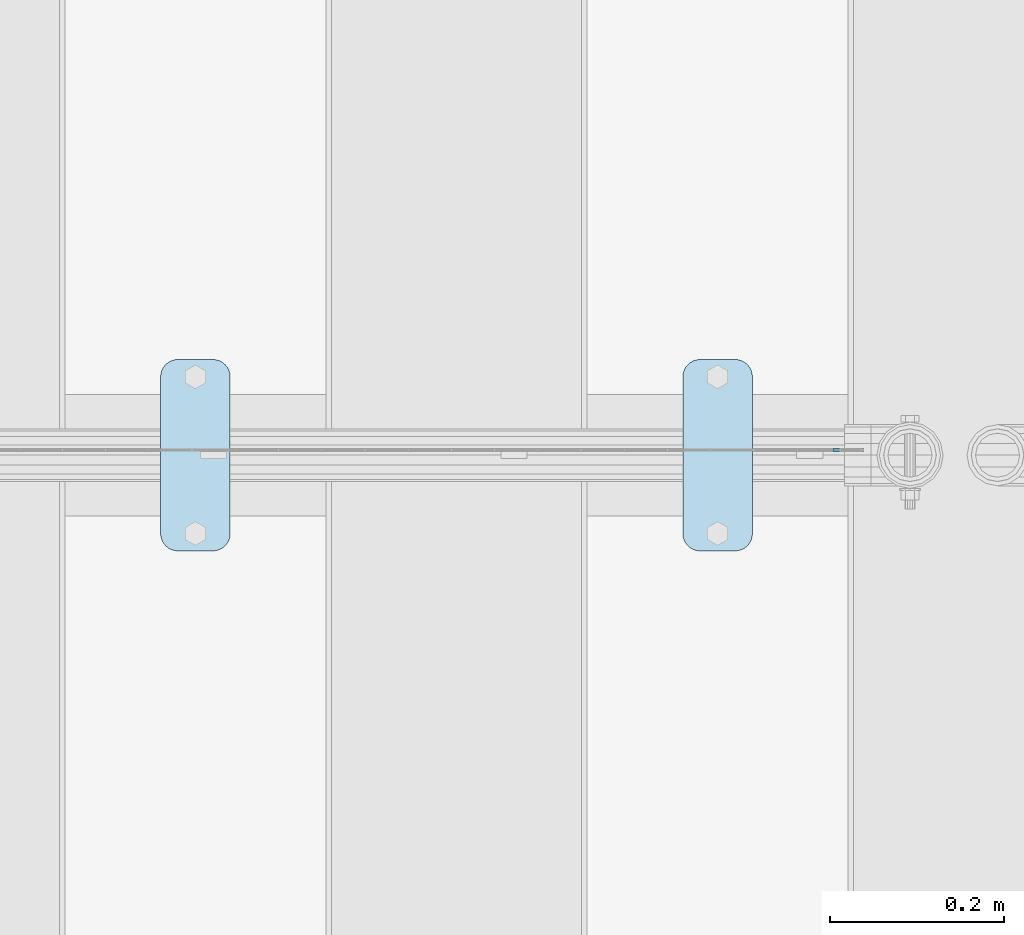
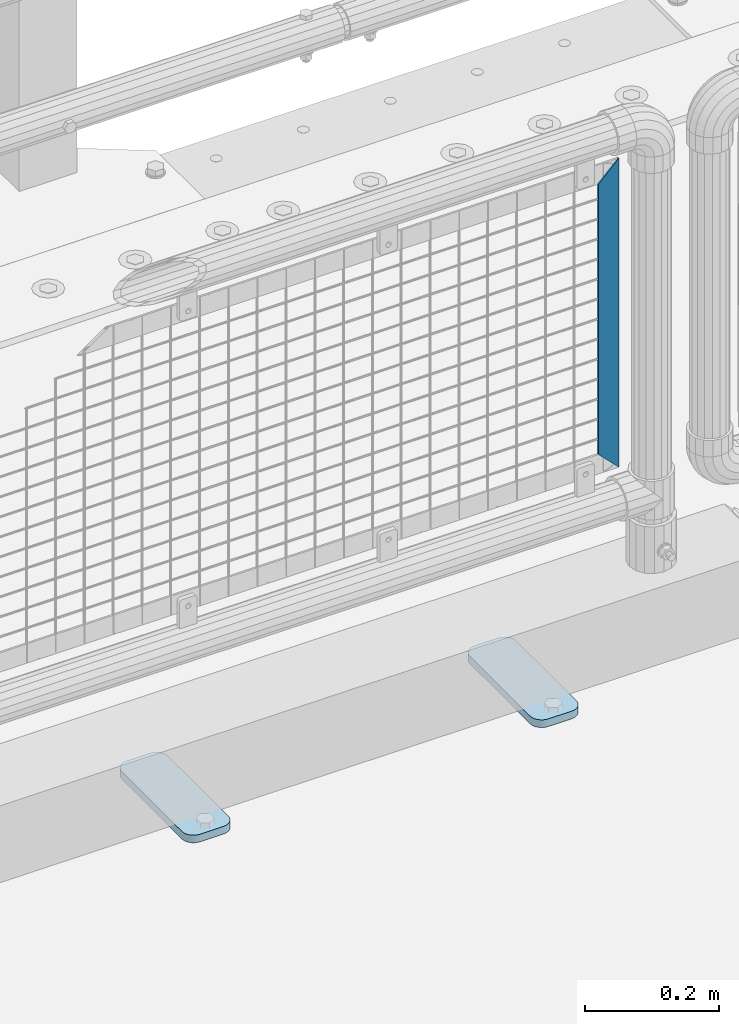
# One storey, part 229 of 257: 3 plates.
"""IFC2X3 building model written with IfcOpenShell, lengths in millimetres."""

from ifc_helpers import new_model, si_unit, frame, origin_with_axes, place, context, subcontext, project, spatial, faceted_brep, material, type_object, element, save


model = new_model("IFC2X3")

# Units and contexts
model_context = context("Model", 3, precision=1e-05, world=origin_with_axes())
body_context = subcontext(model_context, "Body", "Model", "MODEL_VIEW")
ifc_project = project(units=[si_unit("LENGTHUNIT", "METRE", prefix="MILLI"), si_unit("AREAUNIT", "SQUARE_METRE"), si_unit("VOLUMEUNIT", "CUBIC_METRE"), si_unit("MASSUNIT", "GRAM", prefix="KILO"), si_unit("TIMEUNIT", "SECOND"), si_unit("PLANEANGLEUNIT", "RADIAN"), si_unit("SOLIDANGLEUNIT", "STERADIAN"), si_unit("THERMODYNAMICTEMPERATUREUNIT", "DEGREE_CELSIUS"), si_unit("LUMINOUSINTENSITYUNIT", "LUMEN")], contexts=[model_context])

# Site, building, storey
site_placement = place(None, origin_with_axes())
site = spatial("IfcSite", under=ifc_project, at=site_placement, CompositionType="ELEMENT")
building_placement = place(site_placement, origin_with_axes())
building = spatial("IfcBuilding", under=site, at=building_placement, Name="Standard", CompositionType="ELEMENT")
storey_placement = place(building_placement, origin_with_axes())
storey = spatial("IfcBuildingStorey", under=building, at=storey_placement, Name="Undefined", CompositionType="ELEMENT", Elevation=0.0)

# Plates
ifc_material_1 = material(Name="STEEL/S355J2")
plate_type_1 = type_object("IfcPlateType", PredefinedType="NOTDEFINED")
plate_1_placement = place(storey_placement, frame((57210.0, 10774.5, 21.0199999999977), z_axis=(1.0, 0.0, 0.0), x_axis=(0.0, -1.0, 0.0)))
element("IfcPlate", 1, at=plate_1_placement, inside=storey, type_object=plate_type_1, material=ifc_material_1, context=body_context, shape_type="Brep", body=[
    faceted_brep([(0.0, -7.0, 20.0), (0.0, -7.0, 60.0), (0.0, 7.0, 60.0), (0.0, 7.0, 20.0), (0.384294391935327, -7.0, 63.9018064403208), (0.384294391935327, 7.0, 63.9018064403208), (1.52240934977453, -7.0, 67.6536686473046), (1.52240934977453, 7.0, 67.6536686473046), (3.37060775394821, -7.0, 71.1114046603907), (3.37060775394821, 7.0, 71.1114046603907), (5.85786437626848, -7.0, 74.1421356237333), (5.85786437626848, 7.0, 74.1421356237333), (8.88859533960749, -7.0, 76.6293922460536), (8.88859533960749, 7.0, 76.6293922460536), (12.3463313526991, -7.0, 78.4775906502255), (12.3463313526991, 7.0, 78.4775906502255), (16.0981935596774, -7.0, 79.6157056080629), (16.0981935596774, 7.0, 79.6157056080629), (20.0, -7.0, 80.0), (20.0, 7.0, 80.0), (200.0, -7.0, 80.0), (200.0, 7.0, 80.0), (203.901806440323, -7.0, 79.6157056080629), (203.901806440323, 7.0, 79.6157056080629), (207.653668647301, -7.0, 78.4775906502255), (207.653668647301, 7.0, 78.4775906502255), (211.111404660393, -7.0, 76.6293922460536), (211.111404660393, 7.0, 76.6293922460536), (214.142135623732, -7.0, 74.1421356237333), (214.142135623732, 7.0, 74.1421356237333), (216.629392246052, -7.0, 71.1114046603907), (216.629392246052, 7.0, 71.1114046603907), (218.477590650225, -7.0, 67.6536686473046), (218.477590650225, 7.0, 67.6536686473046), (219.615705608065, -7.0, 63.9018064403208), (219.615705608065, 7.0, 63.9018064403208), (220.0, -7.0, 60.0), (220.0, 7.0, 60.0), (220.0, -7.0, 20.0), (220.0, 7.0, 20.0), (219.615705608065, -7.0, 16.0981935596792), (219.615705608065, 7.0, 16.0981935596792), (218.477590650225, -7.0, 12.3463313526954), (218.477590650225, 7.0, 12.3463313526954), (216.629392246052, -7.0, 8.88859533960931), (216.629392246052, 7.0, 8.88859533960931), (214.142135623732, -7.0, 5.85786437626666), (214.142135623732, 7.0, 5.85786437626666), (211.111404660393, -7.0, 3.37060775394639), (211.111404660393, 7.0, 3.37060775394639), (207.653668647301, -7.0, 1.52240934977453), (207.653668647301, 7.0, 1.52240934977453), (203.901806440323, -7.0, 0.384294391937146), (203.901806440323, 7.0, 0.384294391937146), (200.0, -7.0, 0.0), (200.0, 7.0, 0.0), (20.0, -7.0, 0.0), (20.0, 7.0, 0.0), (16.0981935596774, -7.0, 0.384294391937146), (16.0981935596774, 7.0, 0.384294391937146), (12.3463313526991, -7.0, 1.52240934977453), (12.3463313526991, 7.0, 1.52240934977453), (8.88859533960749, -7.0, 3.37060775394639), (8.88859533960749, 7.0, 3.37060775394639), (5.85786437626848, -7.0, 5.85786437626666), (5.85786437626848, 7.0, 5.85786437626666), (3.37060775394821, -7.0, 8.88859533960931), (3.37060775394821, 7.0, 8.88859533960931), (1.52240934977453, -7.0, 12.3463313526954), (1.52240934977453, 7.0, 12.3463313526954), (0.384294391935327, -7.0, 16.0981935596792), (0.384294391935327, 7.0, 16.0981935596792)], [[[0, 1, 2, 3]], [[1, 4, 5, 2]], [[4, 6, 7, 5]], [[6, 8, 9, 7]], [[8, 10, 11, 9]], [[10, 12, 13, 11]], [[12, 14, 15, 13]], [[14, 16, 17, 15]], [[16, 18, 19, 17]], [[18, 20, 21, 19]], [[20, 22, 23, 21]], [[22, 24, 25, 23]], [[24, 26, 27, 25]], [[26, 28, 29, 27]], [[28, 30, 31, 29]], [[30, 32, 33, 31]], [[32, 34, 35, 33]], [[34, 36, 37, 35]], [[36, 38, 39, 37]], [[38, 40, 41, 39]], [[40, 42, 43, 41]], [[42, 44, 45, 43]], [[44, 46, 47, 45]], [[46, 48, 49, 47]], [[48, 50, 51, 49]], [[50, 52, 53, 51]], [[52, 54, 55, 53]], [[54, 56, 57, 55]], [[56, 58, 59, 57]], [[58, 60, 61, 59]], [[60, 62, 63, 61]], [[62, 64, 65, 63]], [[64, 66, 67, 65]], [[66, 68, 69, 67]], [[68, 70, 71, 69]], [[70, 0, 3, 71]], [[5, 7, 9, 11, 13, 15, 17, 19, 21, 23, 25, 27, 29, 31, 33, 35, 37, 39, 41, 43, 45, 47, 49, 51, 53, 55, 57, 59, 61, 63, 65, 67, 69, 71, 3, 2]], [[70, 68, 66, 64, 62, 60, 58, 56, 54, 52, 50, 48, 46, 44, 42, 40, 38, 36, 34, 32, 30, 28, 26, 24, 22, 20, 18, 16, 14, 12, 10, 8, 6, 4, 1, 0]]]),
])
plate_2_placement = place(storey_placement, frame((56610.0, 10774.5, 21.0199999999977), z_axis=(1.0, 0.0, 0.0), x_axis=(0.0, -1.0, 0.0)))
element("IfcPlate", 2, at=plate_2_placement, inside=storey, type_object=plate_type_1, material=ifc_material_1, context=body_context, shape_type="Brep", body=[
    faceted_brep([(0.0, -7.0, 20.0), (0.0, -7.0, 60.0), (0.0, 7.0, 60.0), (0.0, 7.0, 20.0), (0.384294391935327, -7.0, 63.9018064403208), (0.384294391935327, 7.0, 63.9018064403208), (1.52240934977453, -7.0, 67.6536686473046), (1.52240934977453, 7.0, 67.6536686473046), (3.37060775394821, -7.0, 71.1114046603907), (3.37060775394821, 7.0, 71.1114046603907), (5.85786437626848, -7.0, 74.1421356237333), (5.85786437626848, 7.0, 74.1421356237333), (8.88859533960749, -7.0, 76.6293922460536), (8.88859533960749, 7.0, 76.6293922460536), (12.3463313526991, -7.0, 78.4775906502255), (12.3463313526991, 7.0, 78.4775906502255), (16.0981935596774, -7.0, 79.6157056080629), (16.0981935596774, 7.0, 79.6157056080629), (20.0, -7.0, 80.0), (20.0, 7.0, 80.0), (200.0, -7.0, 80.0), (200.0, 7.0, 80.0), (203.901806440323, -7.0, 79.6157056080629), (203.901806440323, 7.0, 79.6157056080629), (207.653668647301, -7.0, 78.4775906502255), (207.653668647301, 7.0, 78.4775906502255), (211.111404660393, -7.0, 76.6293922460536), (211.111404660393, 7.0, 76.6293922460536), (214.142135623732, -7.0, 74.1421356237333), (214.142135623732, 7.0, 74.1421356237333), (216.629392246052, -7.0, 71.1114046603907), (216.629392246052, 7.0, 71.1114046603907), (218.477590650225, -7.0, 67.6536686473046), (218.477590650225, 7.0, 67.6536686473046), (219.615705608065, -7.0, 63.9018064403208), (219.615705608065, 7.0, 63.9018064403208), (220.0, -7.0, 60.0), (220.0, 7.0, 60.0), (220.0, -7.0, 20.0), (220.0, 7.0, 20.0), (219.615705608065, -7.0, 16.0981935596792), (219.615705608065, 7.0, 16.0981935596792), (218.477590650225, -7.0, 12.3463313526954), (218.477590650225, 7.0, 12.3463313526954), (216.629392246052, -7.0, 8.88859533960931), (216.629392246052, 7.0, 8.88859533960931), (214.142135623732, -7.0, 5.85786437626666), (214.142135623732, 7.0, 5.85786437626666), (211.111404660393, -7.0, 3.37060775394639), (211.111404660393, 7.0, 3.37060775394639), (207.653668647301, -7.0, 1.52240934977453), (207.653668647301, 7.0, 1.52240934977453), (203.901806440323, -7.0, 0.384294391937146), (203.901806440323, 7.0, 0.384294391937146), (200.0, -7.0, 0.0), (200.0, 7.0, 0.0), (20.0, -7.0, 0.0), (20.0, 7.0, 0.0), (16.0981935596774, -7.0, 0.384294391937146), (16.0981935596774, 7.0, 0.384294391937146), (12.3463313526991, -7.0, 1.52240934977453), (12.3463313526991, 7.0, 1.52240934977453), (8.88859533960749, -7.0, 3.37060775394639), (8.88859533960749, 7.0, 3.37060775394639), (5.85786437626848, -7.0, 5.85786437626666), (5.85786437626848, 7.0, 5.85786437626666), (3.37060775394821, -7.0, 8.88859533960931), (3.37060775394821, 7.0, 8.88859533960931), (1.52240934977453, -7.0, 12.3463313526954), (1.52240934977453, 7.0, 12.3463313526954), (0.384294391935327, -7.0, 16.0981935596792), (0.384294391935327, 7.0, 16.0981935596792)], [[[0, 1, 2, 3]], [[1, 4, 5, 2]], [[4, 6, 7, 5]], [[6, 8, 9, 7]], [[8, 10, 11, 9]], [[10, 12, 13, 11]], [[12, 14, 15, 13]], [[14, 16, 17, 15]], [[16, 18, 19, 17]], [[18, 20, 21, 19]], [[20, 22, 23, 21]], [[22, 24, 25, 23]], [[24, 26, 27, 25]], [[26, 28, 29, 27]], [[28, 30, 31, 29]], [[30, 32, 33, 31]], [[32, 34, 35, 33]], [[34, 36, 37, 35]], [[36, 38, 39, 37]], [[38, 40, 41, 39]], [[40, 42, 43, 41]], [[42, 44, 45, 43]], [[44, 46, 47, 45]], [[46, 48, 49, 47]], [[48, 50, 51, 49]], [[50, 52, 53, 51]], [[52, 54, 55, 53]], [[54, 56, 57, 55]], [[56, 58, 59, 57]], [[58, 60, 61, 59]], [[60, 62, 63, 61]], [[62, 64, 65, 63]], [[64, 66, 67, 65]], [[66, 68, 69, 67]], [[68, 70, 71, 69]], [[70, 0, 3, 71]], [[5, 7, 9, 11, 13, 15, 17, 19, 21, 23, 25, 27, 29, 31, 33, 35, 37, 39, 41, 43, 45, 47, 49, 51, 53, 55, 57, 59, 61, 63, 65, 67, 69, 71, 3, 2]], [[70, 68, 66, 64, 62, 60, 58, 56, 54, 52, 50, 48, 46, 44, 42, 40, 38, 36, 34, 32, 30, 28, 26, 24, 22, 20, 18, 16, 14, 12, 10, 8, 6, 4, 1, 0]]]),
])
ifc_material_2 = material(Name="Misc_Undefined")
plate_type_2 = type_object("IfcPlateType", PredefinedType="NOTDEFINED")
plate_3_placement = place(storey_placement, frame((57382.4996874836, 10670.5, 879.52), z_axis=(0.707103624179501, 0.0, -0.707109938179499), x_axis=(0.707109938179525, 0.0, 0.707103624179475)))
element("IfcPlate", 3, at=plate_3_placement, inside=storey, type_object=plate_type_2, material=ifc_material_2, context=body_context, shape_type="Brep", body=[
    faceted_brep([(0.0, -1.5, -5.6843418860808e-14), (-348.605163574226, -1.5, 348.602081298828), (-348.605163574226, 1.5, 348.602081298828), (0.0, 1.5, -5.6843418860808e-14), (-348.605163574226, -1.5, 398.099334716804), (-348.605163574226, 1.5, 398.099334716804), (49.4976959228443, -1.5, 6.54836185276508e-11), (49.4976959228443, 1.5, 6.54836185276508e-11)], [[[0, 1, 2, 3]], [[1, 4, 5, 2]], [[4, 6, 7, 5]], [[6, 0, 3, 7]], [[5, 7, 3, 2]], [[6, 4, 1, 0]]]),
])

save(model, "model.ifc")
